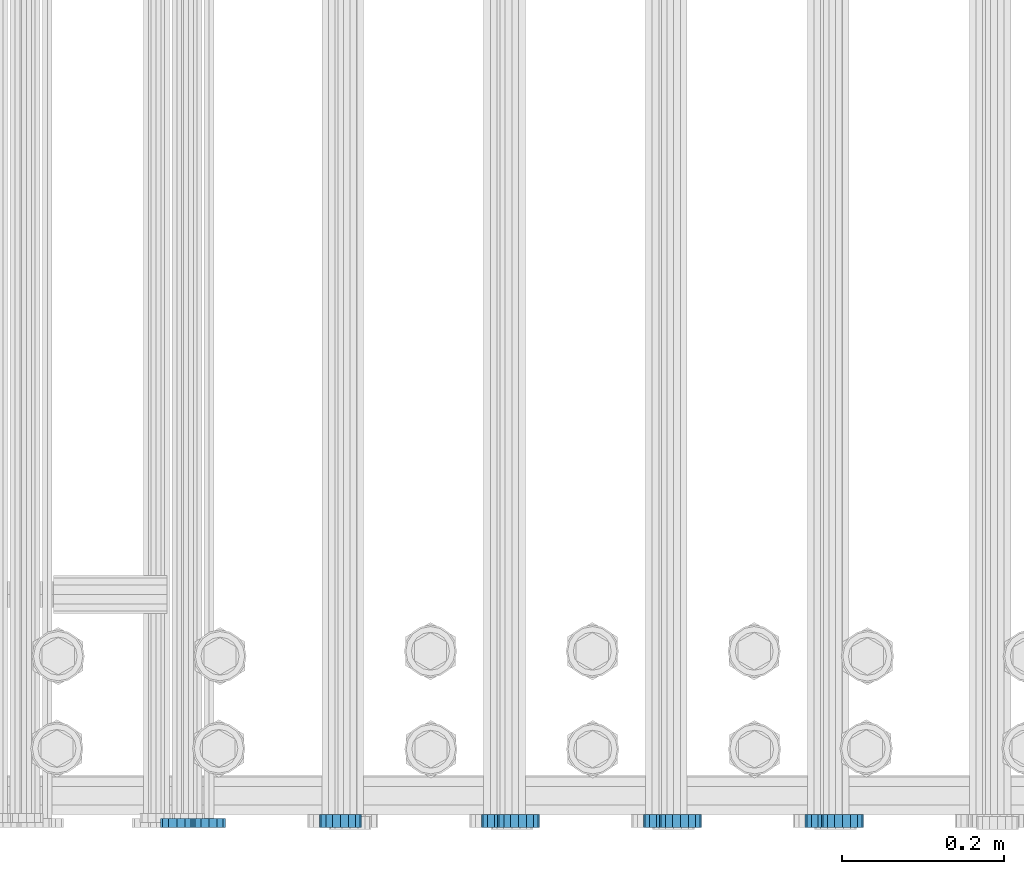
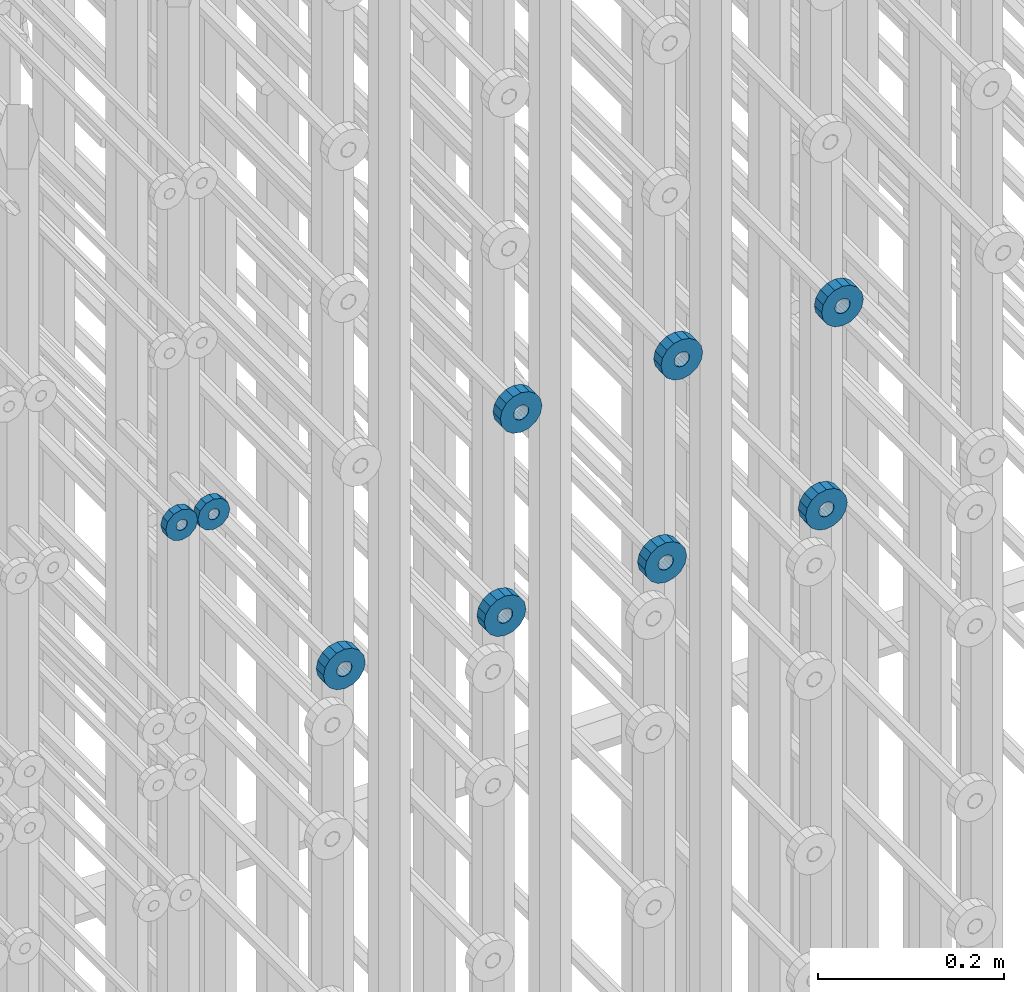
# One storey, part 128 of 177: 9 beams.
"""IFC2X3 building model written with IfcOpenShell, lengths in millimetres."""

from ifc_helpers import new_model, si_unit, frame, origin_with_axes, place, context, subcontext, project, spatial, faceted_brep, material, type_object, element, save


model = new_model("IFC2X3")

# Units and contexts
model_context_1 = context("Model", 3, precision=1e-05, world=origin_with_axes())
model_context_2 = context("Model", 3, precision=1e-05, world=origin_with_axes())
body_context = subcontext(model_context_2, "Body", "Model", "MODEL_VIEW")
ifc_project = project(units=[si_unit("LENGTHUNIT", "METRE", prefix="MILLI"), si_unit("AREAUNIT", "SQUARE_METRE"), si_unit("VOLUMEUNIT", "CUBIC_METRE"), si_unit("MASSUNIT", "GRAM", prefix="KILO"), si_unit("TIMEUNIT", "SECOND"), si_unit("PLANEANGLEUNIT", "RADIAN"), si_unit("SOLIDANGLEUNIT", "STERADIAN"), si_unit("THERMODYNAMICTEMPERATUREUNIT", "DEGREE_CELSIUS"), si_unit("LUMINOUSINTENSITYUNIT", "LUMEN")], contexts=[model_context_1])

# Site, building, storey
site_placement = place(None, origin_with_axes())
site = spatial("IfcSite", under=ifc_project, at=site_placement, CompositionType="ELEMENT")
building_placement = place(site_placement, origin_with_axes())
building = spatial("IfcBuilding", under=site, at=building_placement, Name="Undefined", CompositionType="ELEMENT")
storey_placement = place(building_placement, origin_with_axes())
storey = spatial("IfcBuildingStorey", under=building, at=storey_placement, Name="Undefined", CompositionType="ELEMENT", Elevation=0.0)

# Beams
ifc_material = material(Name="STEEL/Steel_Undefined")
beam_type_1 = type_object("IfcBeamType", PredefinedType="NOTDEFINED")
beam_1_placement = place(storey_placement, frame((2031961.99847313, 6205070.98588033, 21128.9868114202), z_axis=(0.0, 0.0, -1.0), x_axis=(0.0, -1.0, 0.0)))
element("IfcBeam", 1, at=beam_1_placement, inside=storey, type_object=beam_type_1, material=ifc_material, context=body_context, shape_type="Brep", body=[
    faceted_brep([(-3.63797880709171e-12, -7.0, -2.3283064365387e-10), (-8.62348444298797e-13, -6.06217782649107, 3.5), (10.9999999999964, -6.06217782665044, 3.49999999976717), (10.9999999999964, -7.0, -2.3283064365387e-10), (-3.63797880709171e-12, -3.5, 6.06217782618478), (11.0, -3.5, 6.06217782618478), (-1.72469688859759e-12, 0.0, 7.0), (11.0, 0.0, 6.99999999976717), (-3.63797880709171e-12, 3.5, 6.06217782618478), (11.0, 3.5, 6.06217782618478), (-8.62348444298795e-13, 6.06217782649107, 3.5), (10.9999999999964, 6.06217782665044, 3.49999999976717), (-3.63797880709171e-12, 7.0, -2.3283064365387e-10), (10.9999999999964, 7.0, -2.3283064365387e-10), (8.62348444298797e-13, 6.06217782649107, -3.5), (10.9999999999964, 6.06217782665044, -3.50000000023283), (-3.63797880709171e-12, 3.5, -6.06217782665044), (10.9999999999964, 3.5, -6.06217782665044), (1.72469688859759e-12, -2.72004641033163e-15, -7.0), (10.9999999999964, 0.0, -7.00000000023283), (-3.63797880709171e-12, -3.5, -6.06217782665044), (10.9999999999964, -3.5, -6.06217782665044), (8.62348444298796e-13, -6.06217782649107, -3.5), (10.9999999999964, -6.06217782665044, -3.50000000023283), (0.0, -20.0000000009313, 0.0), (0.0, -17.320508075878, -10.0), (10.9999999999964, -17.320508075878, -10.0000000002328), (10.9999999999964, -20.0, -2.3283064365387e-10), (0.0, -10.0000000009313, -17.3205080756452), (11.0, -10.0, -17.320508075878), (0.0, -1.86264514923096e-09, -19.9999999998836), (10.9999999999964, 0.0, -20.0000000002328), (0.0, 9.99999999906868, -17.3205080755288), (11.0, 10.0, -17.320508075878), (0.0, 17.320508075878, -10.0), (10.9999999999964, 17.320508075878, -10.0000000002328), (0.0, 19.9999999990687, 0.0), (10.9999999999964, 20.0, -2.3283064365387e-10), (0.0, 17.3205080740154, 10.0), (11.0, 17.320508075878, 9.99999999976717), (0.0, 9.99999999906868, 17.3205080757616), (10.9999999999964, 10.0, 17.3205080754124), (0.0, 0.0, 20.0000000001164), (10.9999999999964, 0.0, 19.9999999997672), (0.0, -10.0000000009313, 17.3205080757616), (10.9999999999964, -10.0, 17.3205080754124), (0.0, -17.3205080777407, 10.0000000001164), (11.0, -17.320508075878, 9.99999999976717)], [[[0, 1, 2, 3]], [[1, 4, 5, 2]], [[4, 6, 7, 5]], [[6, 8, 9, 7]], [[8, 10, 11, 9]], [[10, 12, 13, 11]], [[12, 14, 15, 13]], [[14, 16, 17, 15]], [[16, 18, 19, 17]], [[18, 20, 21, 19]], [[20, 22, 23, 21]], [[22, 0, 3, 23]], [[24, 25, 26, 27]], [[25, 28, 29, 26]], [[28, 30, 31, 29]], [[30, 32, 33, 31]], [[32, 34, 35, 33]], [[34, 36, 37, 35]], [[36, 38, 39, 37]], [[38, 40, 41, 39]], [[40, 42, 43, 41]], [[42, 44, 45, 43]], [[44, 46, 47, 45]], [[46, 24, 27, 47]], [[29, 31, 33, 35, 37, 39, 41, 43, 45, 47, 27, 26], [5, 7, 9, 11, 13, 15, 17, 19, 21, 23, 3, 2]], [[46, 44, 42, 40, 38, 36, 34, 32, 30, 28, 25, 24], [22, 20, 18, 16, 14, 12, 10, 8, 6, 4, 1, 0]]]),
])
beam_2_placement = place(storey_placement, frame((2031921.99847313, 6205070.98588033, 21128.9868114202), z_axis=(0.0, 0.0, -1.0), x_axis=(0.0, -1.0, 0.0)))
element("IfcBeam", 2, at=beam_2_placement, inside=storey, type_object=beam_type_1, material=ifc_material, context=body_context, shape_type="Brep", body=[
    faceted_brep([(-3.63797880709171e-12, -7.0, -2.3283064365387e-10), (-8.62348444298797e-13, -6.06217782649107, 3.5), (10.9999999999964, -6.06217782665044, 3.49999999976717), (10.9999999999964, -7.0, -2.3283064365387e-10), (-3.63797880709171e-12, -3.5, 6.06217782618478), (11.0, -3.5, 6.06217782618478), (-1.72469688859759e-12, 0.0, 7.0), (11.0, 0.0, 6.99999999976717), (-3.63797880709171e-12, 3.5, 6.06217782618478), (11.0, 3.5, 6.06217782618478), (-8.62348444298795e-13, 6.06217782649107, 3.5), (10.9999999999964, 6.06217782665044, 3.49999999976717), (-3.63797880709171e-12, 7.0, -2.3283064365387e-10), (10.9999999999964, 7.0, -2.3283064365387e-10), (8.62348444298797e-13, 6.06217782649107, -3.5), (10.9999999999964, 6.06217782665044, -3.50000000023283), (-3.63797880709171e-12, 3.5, -6.06217782665044), (10.9999999999964, 3.5, -6.06217782665044), (1.72469688859759e-12, -2.72004641033163e-15, -7.0), (10.9999999999964, 0.0, -7.00000000023283), (-3.63797880709171e-12, -3.5, -6.06217782665044), (10.9999999999964, -3.5, -6.06217782665044), (8.62348444298796e-13, -6.06217782649107, -3.5), (10.9999999999964, -6.06217782665044, -3.50000000023283), (0.0, -20.0000000009313, 0.0), (0.0, -17.320508075878, -10.0), (10.9999999999964, -17.320508075878, -10.0000000002328), (10.9999999999964, -20.0, -2.3283064365387e-10), (0.0, -10.0000000009313, -17.3205080756452), (11.0, -10.0, -17.320508075878), (0.0, -1.86264514923096e-09, -19.9999999998836), (10.9999999999964, 0.0, -20.0000000002328), (0.0, 9.99999999906868, -17.3205080755288), (11.0, 10.0, -17.320508075878), (0.0, 17.320508075878, -10.0), (10.9999999999964, 17.320508075878, -10.0000000002328), (0.0, 19.9999999990687, 0.0), (10.9999999999964, 20.0, -2.3283064365387e-10), (0.0, 17.3205080740154, 10.0), (11.0, 17.320508075878, 9.99999999976717), (0.0, 9.99999999906868, 17.3205080757616), (10.9999999999964, 10.0, 17.3205080754124), (0.0, 0.0, 20.0000000001164), (10.9999999999964, 0.0, 19.9999999997672), (0.0, -10.0000000009313, 17.3205080757616), (10.9999999999964, -10.0, 17.3205080754124), (0.0, -17.3205080777407, 10.0000000001164), (11.0, -17.320508075878, 9.99999999976717)], [[[0, 1, 2, 3]], [[1, 4, 5, 2]], [[4, 6, 7, 5]], [[6, 8, 9, 7]], [[8, 10, 11, 9]], [[10, 12, 13, 11]], [[12, 14, 15, 13]], [[14, 16, 17, 15]], [[16, 18, 19, 17]], [[18, 20, 21, 19]], [[20, 22, 23, 21]], [[22, 0, 3, 23]], [[24, 25, 26, 27]], [[25, 28, 29, 26]], [[28, 30, 31, 29]], [[30, 32, 33, 31]], [[32, 34, 35, 33]], [[34, 36, 37, 35]], [[36, 38, 39, 37]], [[38, 40, 41, 39]], [[40, 42, 43, 41]], [[42, 44, 45, 43]], [[44, 46, 47, 45]], [[46, 24, 27, 47]], [[29, 31, 33, 35, 37, 39, 41, 43, 45, 47, 27, 26], [5, 7, 9, 11, 13, 15, 17, 19, 21, 23, 3, 2]], [[46, 44, 42, 40, 38, 36, 34, 32, 30, 28, 25, 24], [22, 20, 18, 16, 14, 12, 10, 8, 6, 4, 1, 0]]]),
])
beam_type_2 = type_object("IfcBeamType", PredefinedType="NOTDEFINED")
beam_3_placement = place(storey_placement, frame((2032724.49847313, 6205075.98588568, 20868.4868124751), z_axis=(0.0, 0.0, -1.0), x_axis=(0.0, -1.0, 0.0)))
element("IfcBeam", 3, at=beam_3_placement, inside=storey, type_object=beam_type_2, material=ifc_material, context=body_context, shape_type="Brep", body=[
    faceted_brep([(0.0, -9.5, 0.0), (0.0, -8.77685555908829, 3.63549260746731), (16.0, -8.77685555908829, 3.63549260746731), (16.0, -9.5, 0.0), (0.0, -6.71751442085952, 6.71751442127061), (16.0, -6.71751442085952, 6.71751442127061), (0.0, -3.63549260701984, 8.77685555885546), (16.0, -3.63549260701984, 8.77685555885546), (-2.02452244836415e-12, 0.0, 9.5), (16.0, 0.0, 9.5), (0.0, 3.63549260701984, 8.77685555885546), (16.0, 3.63549260701984, 8.77685555885546), (0.0, 6.71751442085952, 6.71751442127061), (16.0, 6.71751442085952, 6.71751442127061), (0.0, 8.77685555908829, 3.63549260746731), (16.0, 8.77685555908829, 3.63549260746731), (0.0, 9.5, 0.0), (16.0, 9.5, 0.0), (0.0, 8.77685555908829, -3.63549260746731), (16.0, 8.77685555908829, -3.63549260746731), (0.0, 6.71751442085952, -6.71751442127061), (16.0, 6.71751442085952, -6.71751442127061), (0.0, 3.63549260701984, -8.77685555885546), (16.0, 3.63549260701984, -8.77685555885546), (2.02452244836415e-12, -3.69149155687865e-15, -9.5), (16.0, 0.0, -9.5), (0.0, -3.63549260701984, -8.77685555885546), (16.0, -3.63549260701984, -8.77685555885546), (0.0, -6.71751442085952, -6.71751442127061), (16.0, -6.71751442085952, -6.71751442127061), (0.0, -8.77685555908829, -3.63549260746731), (16.0, -8.77685555908829, -3.63549260746731), (0.0, -26.0, 0.0), (0.0, -24.0208678450435, -9.94976924149159), (16.0, -24.0208678450435, -9.94976924149159), (16.0, -26.0, 0.0), (0.0, -18.3847763109952, -18.3847763108497), (16.0, -18.3847763109952, -18.3847763108497), (0.0, -9.94976924173534, -24.0208678452946), (16.0, -9.94976924173534, -24.0208678452946), (0.0, 0.0, -26.0), (16.0, 0.0, -26.0), (0.0, 9.94976924173534, -24.0208678452946), (16.0, 9.94976924173534, -24.0208678452946), (0.0, 18.3847763109952, -18.3847763108497), (16.0, 18.3847763109952, -18.3847763108497), (0.0, 24.0208678450435, -9.94976924149159), (16.0, 24.0208678450435, -9.94976924149159), (0.0, 26.0, 0.0), (16.0, 26.0, 0.0), (0.0, 24.0208678450435, 9.94976924149159), (16.0, 24.0208678450435, 9.94976924149159), (0.0, 18.3847763109952, 18.3847763108497), (16.0, 18.3847763109952, 18.3847763108497), (0.0, 9.94976924173534, 24.0208678452946), (16.0, 9.94976924173534, 24.0208678452946), (0.0, 0.0, 26.0), (16.0, 0.0, 26.0), (0.0, -9.94976924173534, 24.0208678452946), (16.0, -9.94976924173534, 24.0208678452946), (0.0, -18.3847763109952, 18.3847763108497), (16.0, -18.3847763109952, 18.3847763108497), (0.0, -24.0208678450435, 9.94976924149159), (16.0, -24.0208678450435, 9.94976924149159)], [[[0, 1, 2, 3]], [[1, 4, 5, 2]], [[4, 6, 7, 5]], [[6, 8, 9, 7]], [[8, 10, 11, 9]], [[10, 12, 13, 11]], [[12, 14, 15, 13]], [[14, 16, 17, 15]], [[16, 18, 19, 17]], [[18, 20, 21, 19]], [[20, 22, 23, 21]], [[22, 24, 25, 23]], [[24, 26, 27, 25]], [[26, 28, 29, 27]], [[28, 30, 31, 29]], [[30, 0, 3, 31]], [[32, 33, 34, 35]], [[33, 36, 37, 34]], [[36, 38, 39, 37]], [[38, 40, 41, 39]], [[40, 42, 43, 41]], [[42, 44, 45, 43]], [[44, 46, 47, 45]], [[46, 48, 49, 47]], [[48, 50, 51, 49]], [[50, 52, 53, 51]], [[52, 54, 55, 53]], [[54, 56, 57, 55]], [[56, 58, 59, 57]], [[58, 60, 61, 59]], [[60, 62, 63, 61]], [[62, 32, 35, 63]], [[37, 39, 41, 43, 45, 47, 49, 51, 53, 55, 57, 59, 61, 63, 35, 34], [5, 7, 9, 11, 13, 15, 17, 19, 21, 23, 25, 27, 29, 31, 3, 2]], [[62, 60, 58, 56, 54, 52, 50, 48, 46, 44, 42, 40, 38, 36, 33, 32], [30, 28, 26, 24, 22, 20, 18, 16, 14, 12, 10, 8, 6, 4, 1, 0]]]),
])
beam_4_placement = place(storey_placement, frame((2032524.49847313, 6205075.98588568, 20868.4868124752), z_axis=(0.0, 0.0, -1.0), x_axis=(0.0, -1.0, 0.0)))
element("IfcBeam", 4, at=beam_4_placement, inside=storey, type_object=beam_type_2, material=ifc_material, context=body_context, shape_type="Brep", body=[
    faceted_brep([(0.0, -9.5, 0.0), (0.0, -8.77685555908829, 3.63549260746731), (16.0, -8.77685555908829, 3.63549260746731), (16.0, -9.5, 0.0), (0.0, -6.71751442085952, 6.71751442127061), (16.0, -6.71751442085952, 6.71751442127061), (0.0, -3.63549260701984, 8.77685555885546), (16.0, -3.63549260701984, 8.77685555885546), (-2.02452244836415e-12, 0.0, 9.5), (16.0, 0.0, 9.5), (0.0, 3.63549260701984, 8.77685555885546), (16.0, 3.63549260701984, 8.77685555885546), (0.0, 6.71751442085952, 6.71751442127061), (16.0, 6.71751442085952, 6.71751442127061), (0.0, 8.77685555908829, 3.63549260746731), (16.0, 8.77685555908829, 3.63549260746731), (0.0, 9.5, 0.0), (16.0, 9.5, 0.0), (0.0, 8.77685555908829, -3.63549260746731), (16.0, 8.77685555908829, -3.63549260746731), (0.0, 6.71751442085952, -6.71751442127061), (16.0, 6.71751442085952, -6.71751442127061), (0.0, 3.63549260701984, -8.77685555885546), (16.0, 3.63549260701984, -8.77685555885546), (2.02452244836415e-12, -3.69149155687865e-15, -9.5), (16.0, 0.0, -9.5), (0.0, -3.63549260701984, -8.77685555885546), (16.0, -3.63549260701984, -8.77685555885546), (0.0, -6.71751442085952, -6.71751442127061), (16.0, -6.71751442085952, -6.71751442127061), (0.0, -8.77685555908829, -3.63549260746731), (16.0, -8.77685555908829, -3.63549260746731), (0.0, -26.0, 0.0), (0.0, -24.0208678450435, -9.94976924149159), (16.0, -24.0208678450435, -9.94976924149159), (16.0, -26.0, 0.0), (0.0, -18.3847763109952, -18.3847763108497), (16.0, -18.3847763109952, -18.3847763108497), (0.0, -9.94976924173534, -24.0208678452946), (16.0, -9.94976924173534, -24.0208678452946), (0.0, 0.0, -26.0), (16.0, 0.0, -26.0), (0.0, 9.94976924173534, -24.0208678452946), (16.0, 9.94976924173534, -24.0208678452946), (0.0, 18.3847763109952, -18.3847763108497), (16.0, 18.3847763109952, -18.3847763108497), (0.0, 24.0208678450435, -9.94976924149159), (16.0, 24.0208678450435, -9.94976924149159), (0.0, 26.0, 0.0), (16.0, 26.0, 0.0), (0.0, 24.0208678450435, 9.94976924149159), (16.0, 24.0208678450435, 9.94976924149159), (0.0, 18.3847763109952, 18.3847763108497), (16.0, 18.3847763109952, 18.3847763108497), (0.0, 9.94976924173534, 24.0208678452946), (16.0, 9.94976924173534, 24.0208678452946), (0.0, 0.0, 26.0), (16.0, 0.0, 26.0), (0.0, -9.94976924173534, 24.0208678452946), (16.0, -9.94976924173534, 24.0208678452946), (0.0, -18.3847763109952, 18.3847763108497), (16.0, -18.3847763109952, 18.3847763108497), (0.0, -24.0208678450435, 9.94976924149159), (16.0, -24.0208678450435, 9.94976924149159)], [[[0, 1, 2, 3]], [[1, 4, 5, 2]], [[4, 6, 7, 5]], [[6, 8, 9, 7]], [[8, 10, 11, 9]], [[10, 12, 13, 11]], [[12, 14, 15, 13]], [[14, 16, 17, 15]], [[16, 18, 19, 17]], [[18, 20, 21, 19]], [[20, 22, 23, 21]], [[22, 24, 25, 23]], [[24, 26, 27, 25]], [[26, 28, 29, 27]], [[28, 30, 31, 29]], [[30, 0, 3, 31]], [[32, 33, 34, 35]], [[33, 36, 37, 34]], [[36, 38, 39, 37]], [[38, 40, 41, 39]], [[40, 42, 43, 41]], [[42, 44, 45, 43]], [[44, 46, 47, 45]], [[46, 48, 49, 47]], [[48, 50, 51, 49]], [[50, 52, 53, 51]], [[52, 54, 55, 53]], [[54, 56, 57, 55]], [[56, 58, 59, 57]], [[58, 60, 61, 59]], [[60, 62, 63, 61]], [[62, 32, 35, 63]], [[37, 39, 41, 43, 45, 47, 49, 51, 53, 55, 57, 59, 61, 63, 35, 34], [5, 7, 9, 11, 13, 15, 17, 19, 21, 23, 25, 27, 29, 31, 3, 2]], [[62, 60, 58, 56, 54, 52, 50, 48, 46, 44, 42, 40, 38, 36, 33, 32], [30, 28, 26, 24, 22, 20, 18, 16, 14, 12, 10, 8, 6, 4, 1, 0]]]),
])
beam_5_placement = place(storey_placement, frame((2032324.49847313, 6205075.98588568, 20868.4868124752), z_axis=(0.0, 0.0, -1.0), x_axis=(0.0, -1.0, 0.0)))
element("IfcBeam", 5, at=beam_5_placement, inside=storey, type_object=beam_type_2, material=ifc_material, context=body_context, shape_type="Brep", body=[
    faceted_brep([(0.0, -9.5, 0.0), (0.0, -8.77685555908829, 3.63549260746731), (16.0, -8.77685555908829, 3.63549260746731), (16.0, -9.5, 0.0), (0.0, -6.71751442085952, 6.71751442127061), (16.0, -6.71751442085952, 6.71751442127061), (0.0, -3.63549260701984, 8.77685555885546), (16.0, -3.63549260701984, 8.77685555885546), (-2.02452244836415e-12, 0.0, 9.5), (16.0, 0.0, 9.5), (0.0, 3.63549260701984, 8.77685555885546), (16.0, 3.63549260701984, 8.77685555885546), (0.0, 6.71751442085952, 6.71751442127061), (16.0, 6.71751442085952, 6.71751442127061), (0.0, 8.77685555908829, 3.63549260746731), (16.0, 8.77685555908829, 3.63549260746731), (0.0, 9.5, 0.0), (16.0, 9.5, 0.0), (0.0, 8.77685555908829, -3.63549260746731), (16.0, 8.77685555908829, -3.63549260746731), (0.0, 6.71751442085952, -6.71751442127061), (16.0, 6.71751442085952, -6.71751442127061), (0.0, 3.63549260701984, -8.77685555885546), (16.0, 3.63549260701984, -8.77685555885546), (2.02452244836415e-12, -3.69149155687865e-15, -9.5), (16.0, 0.0, -9.5), (0.0, -3.63549260701984, -8.77685555885546), (16.0, -3.63549260701984, -8.77685555885546), (0.0, -6.71751442085952, -6.71751442127061), (16.0, -6.71751442085952, -6.71751442127061), (0.0, -8.77685555908829, -3.63549260746731), (16.0, -8.77685555908829, -3.63549260746731), (0.0, -26.0, 0.0), (0.0, -24.0208678450435, -9.94976924149159), (16.0, -24.0208678450435, -9.94976924149159), (16.0, -26.0, 0.0), (0.0, -18.3847763109952, -18.3847763108497), (16.0, -18.3847763109952, -18.3847763108497), (0.0, -9.94976924173534, -24.0208678452946), (16.0, -9.94976924173534, -24.0208678452946), (0.0, 0.0, -26.0), (16.0, 0.0, -26.0), (0.0, 9.94976924173534, -24.0208678452946), (16.0, 9.94976924173534, -24.0208678452946), (0.0, 18.3847763109952, -18.3847763108497), (16.0, 18.3847763109952, -18.3847763108497), (0.0, 24.0208678450435, -9.94976924149159), (16.0, 24.0208678450435, -9.94976924149159), (0.0, 26.0, 0.0), (16.0, 26.0, 0.0), (0.0, 24.0208678450435, 9.94976924149159), (16.0, 24.0208678450435, 9.94976924149159), (0.0, 18.3847763109952, 18.3847763108497), (16.0, 18.3847763109952, 18.3847763108497), (0.0, 9.94976924173534, 24.0208678452946), (16.0, 9.94976924173534, 24.0208678452946), (0.0, 0.0, 26.0), (16.0, 0.0, 26.0), (0.0, -9.94976924173534, 24.0208678452946), (16.0, -9.94976924173534, 24.0208678452946), (0.0, -18.3847763109952, 18.3847763108497), (16.0, -18.3847763109952, 18.3847763108497), (0.0, -24.0208678450435, 9.94976924149159), (16.0, -24.0208678450435, 9.94976924149159)], [[[0, 1, 2, 3]], [[1, 4, 5, 2]], [[4, 6, 7, 5]], [[6, 8, 9, 7]], [[8, 10, 11, 9]], [[10, 12, 13, 11]], [[12, 14, 15, 13]], [[14, 16, 17, 15]], [[16, 18, 19, 17]], [[18, 20, 21, 19]], [[20, 22, 23, 21]], [[22, 24, 25, 23]], [[24, 26, 27, 25]], [[26, 28, 29, 27]], [[28, 30, 31, 29]], [[30, 0, 3, 31]], [[32, 33, 34, 35]], [[33, 36, 37, 34]], [[36, 38, 39, 37]], [[38, 40, 41, 39]], [[40, 42, 43, 41]], [[42, 44, 45, 43]], [[44, 46, 47, 45]], [[46, 48, 49, 47]], [[48, 50, 51, 49]], [[50, 52, 53, 51]], [[52, 54, 55, 53]], [[54, 56, 57, 55]], [[56, 58, 59, 57]], [[58, 60, 61, 59]], [[60, 62, 63, 61]], [[62, 32, 35, 63]], [[37, 39, 41, 43, 45, 47, 49, 51, 53, 55, 57, 59, 61, 63, 35, 34], [5, 7, 9, 11, 13, 15, 17, 19, 21, 23, 25, 27, 29, 31, 3, 2]], [[62, 60, 58, 56, 54, 52, 50, 48, 46, 44, 42, 40, 38, 36, 33, 32], [30, 28, 26, 24, 22, 20, 18, 16, 14, 12, 10, 8, 6, 4, 1, 0]]]),
])
beam_6_placement = place(storey_placement, frame((2032124.49847313, 6205075.98588568, 20868.4868124752), z_axis=(0.0, 0.0, -1.0), x_axis=(0.0, -1.0, 0.0)))
element("IfcBeam", 6, at=beam_6_placement, inside=storey, type_object=beam_type_2, material=ifc_material, context=body_context, shape_type="Brep", body=[
    faceted_brep([(0.0, -9.5, 0.0), (0.0, -8.77685555908829, 3.63549260746731), (16.0, -8.77685555908829, 3.63549260746731), (16.0, -9.5, 0.0), (0.0, -6.71751442085952, 6.71751442127061), (16.0, -6.71751442085952, 6.71751442127061), (0.0, -3.63549260701984, 8.77685555885546), (16.0, -3.63549260701984, 8.77685555885546), (-2.02452244836415e-12, 0.0, 9.5), (16.0, 0.0, 9.5), (0.0, 3.63549260701984, 8.77685555885546), (16.0, 3.63549260701984, 8.77685555885546), (0.0, 6.71751442085952, 6.71751442127061), (16.0, 6.71751442085952, 6.71751442127061), (0.0, 8.77685555908829, 3.63549260746731), (16.0, 8.77685555908829, 3.63549260746731), (0.0, 9.5, 0.0), (16.0, 9.5, 0.0), (0.0, 8.77685555908829, -3.63549260746731), (16.0, 8.77685555908829, -3.63549260746731), (0.0, 6.71751442085952, -6.71751442127061), (16.0, 6.71751442085952, -6.71751442127061), (0.0, 3.63549260701984, -8.77685555885546), (16.0, 3.63549260701984, -8.77685555885546), (2.02452244836415e-12, -3.69149155687865e-15, -9.5), (16.0, 0.0, -9.5), (0.0, -3.63549260701984, -8.77685555885546), (16.0, -3.63549260701984, -8.77685555885546), (0.0, -6.71751442085952, -6.71751442127061), (16.0, -6.71751442085952, -6.71751442127061), (0.0, -8.77685555908829, -3.63549260746731), (16.0, -8.77685555908829, -3.63549260746731), (0.0, -26.0, 0.0), (0.0, -24.0208678450435, -9.94976924149159), (16.0, -24.0208678450435, -9.94976924149159), (16.0, -26.0, 0.0), (0.0, -18.3847763109952, -18.3847763108497), (16.0, -18.3847763109952, -18.3847763108497), (0.0, -9.94976924173534, -24.0208678452946), (16.0, -9.94976924173534, -24.0208678452946), (0.0, 0.0, -26.0), (16.0, 0.0, -26.0), (0.0, 9.94976924173534, -24.0208678452946), (16.0, 9.94976924173534, -24.0208678452946), (0.0, 18.3847763109952, -18.3847763108497), (16.0, 18.3847763109952, -18.3847763108497), (0.0, 24.0208678450435, -9.94976924149159), (16.0, 24.0208678450435, -9.94976924149159), (0.0, 26.0, 0.0), (16.0, 26.0, 0.0), (0.0, 24.0208678450435, 9.94976924149159), (16.0, 24.0208678450435, 9.94976924149159), (0.0, 18.3847763109952, 18.3847763108497), (16.0, 18.3847763109952, 18.3847763108497), (0.0, 9.94976924173534, 24.0208678452946), (16.0, 9.94976924173534, 24.0208678452946), (0.0, 0.0, 26.0), (16.0, 0.0, 26.0), (0.0, -9.94976924173534, 24.0208678452946), (16.0, -9.94976924173534, 24.0208678452946), (0.0, -18.3847763109952, 18.3847763108497), (16.0, -18.3847763109952, 18.3847763108497), (0.0, -24.0208678450435, 9.94976924149159), (16.0, -24.0208678450435, 9.94976924149159)], [[[0, 1, 2, 3]], [[1, 4, 5, 2]], [[4, 6, 7, 5]], [[6, 8, 9, 7]], [[8, 10, 11, 9]], [[10, 12, 13, 11]], [[12, 14, 15, 13]], [[14, 16, 17, 15]], [[16, 18, 19, 17]], [[18, 20, 21, 19]], [[20, 22, 23, 21]], [[22, 24, 25, 23]], [[24, 26, 27, 25]], [[26, 28, 29, 27]], [[28, 30, 31, 29]], [[30, 0, 3, 31]], [[32, 33, 34, 35]], [[33, 36, 37, 34]], [[36, 38, 39, 37]], [[38, 40, 41, 39]], [[40, 42, 43, 41]], [[42, 44, 45, 43]], [[44, 46, 47, 45]], [[46, 48, 49, 47]], [[48, 50, 51, 49]], [[50, 52, 53, 51]], [[52, 54, 55, 53]], [[54, 56, 57, 55]], [[56, 58, 59, 57]], [[58, 60, 61, 59]], [[60, 62, 63, 61]], [[62, 32, 35, 63]], [[37, 39, 41, 43, 45, 47, 49, 51, 53, 55, 57, 59, 61, 63, 35, 34], [5, 7, 9, 11, 13, 15, 17, 19, 21, 23, 25, 27, 29, 31, 3, 2]], [[62, 60, 58, 56, 54, 52, 50, 48, 46, 44, 42, 40, 38, 36, 33, 32], [30, 28, 26, 24, 22, 20, 18, 16, 14, 12, 10, 8, 6, 4, 1, 0]]]),
])
beam_7_placement = place(storey_placement, frame((2032744.49847313, 6205075.98588578, 21128.9868125736), z_axis=(0.0, 0.0, -1.0), x_axis=(0.0, -1.0, 0.0)))
element("IfcBeam", 7, at=beam_7_placement, inside=storey, type_object=beam_type_2, material=ifc_material, context=body_context, shape_type="Brep", body=[
    faceted_brep([(0.0, -9.5, 0.0), (0.0, -8.77685555908829, 3.63549260746731), (16.0, -8.77685555908829, 3.63549260746731), (16.0, -9.5, 0.0), (0.0, -6.71751442085952, 6.71751442127061), (16.0, -6.71751442085952, 6.71751442127061), (0.0, -3.63549260701984, 8.77685555885546), (16.0, -3.63549260701984, 8.77685555885546), (-2.02452244836415e-12, 0.0, 9.5), (16.0, 0.0, 9.5), (0.0, 3.63549260701984, 8.77685555885546), (16.0, 3.63549260701984, 8.77685555885546), (0.0, 6.71751442085952, 6.71751442127061), (16.0, 6.71751442085952, 6.71751442127061), (0.0, 8.77685555908829, 3.63549260746731), (16.0, 8.77685555908829, 3.63549260746731), (0.0, 9.5, 0.0), (16.0, 9.5, 0.0), (0.0, 8.77685555908829, -3.63549260746731), (16.0, 8.77685555908829, -3.63549260746731), (0.0, 6.71751442085952, -6.71751442127061), (16.0, 6.71751442085952, -6.71751442127061), (0.0, 3.63549260701984, -8.77685555885546), (16.0, 3.63549260701984, -8.77685555885546), (2.02452244836415e-12, -3.69149155687865e-15, -9.5), (16.0, 0.0, -9.5), (0.0, -3.63549260701984, -8.77685555885546), (16.0, -3.63549260701984, -8.77685555885546), (0.0, -6.71751442085952, -6.71751442127061), (16.0, -6.71751442085952, -6.71751442127061), (0.0, -8.77685555908829, -3.63549260746731), (16.0, -8.77685555908829, -3.63549260746731), (0.0, -26.0, 0.0), (0.0, -24.0208678450435, -9.94976924149159), (16.0, -24.0208678450435, -9.94976924149159), (16.0, -26.0, 0.0), (0.0, -18.3847763109952, -18.3847763108497), (16.0, -18.3847763109952, -18.3847763108497), (0.0, -9.94976924173534, -24.0208678452946), (16.0, -9.94976924173534, -24.0208678452946), (0.0, 0.0, -26.0), (16.0, 0.0, -26.0), (0.0, 9.94976924173534, -24.0208678452946), (16.0, 9.94976924173534, -24.0208678452946), (0.0, 18.3847763109952, -18.3847763108497), (16.0, 18.3847763109952, -18.3847763108497), (0.0, 24.0208678450435, -9.94976924149159), (16.0, 24.0208678450435, -9.94976924149159), (0.0, 26.0, 0.0), (16.0, 26.0, 0.0), (0.0, 24.0208678450435, 9.94976924149159), (16.0, 24.0208678450435, 9.94976924149159), (0.0, 18.3847763109952, 18.3847763108497), (16.0, 18.3847763109952, 18.3847763108497), (0.0, 9.94976924173534, 24.0208678452946), (16.0, 9.94976924173534, 24.0208678452946), (0.0, 0.0, 26.0), (16.0, 0.0, 26.0), (0.0, -9.94976924173534, 24.0208678452946), (16.0, -9.94976924173534, 24.0208678452946), (0.0, -18.3847763109952, 18.3847763108497), (16.0, -18.3847763109952, 18.3847763108497), (0.0, -24.0208678450435, 9.94976924149159), (16.0, -24.0208678450435, 9.94976924149159)], [[[0, 1, 2, 3]], [[1, 4, 5, 2]], [[4, 6, 7, 5]], [[6, 8, 9, 7]], [[8, 10, 11, 9]], [[10, 12, 13, 11]], [[12, 14, 15, 13]], [[14, 16, 17, 15]], [[16, 18, 19, 17]], [[18, 20, 21, 19]], [[20, 22, 23, 21]], [[22, 24, 25, 23]], [[24, 26, 27, 25]], [[26, 28, 29, 27]], [[28, 30, 31, 29]], [[30, 0, 3, 31]], [[32, 33, 34, 35]], [[33, 36, 37, 34]], [[36, 38, 39, 37]], [[38, 40, 41, 39]], [[40, 42, 43, 41]], [[42, 44, 45, 43]], [[44, 46, 47, 45]], [[46, 48, 49, 47]], [[48, 50, 51, 49]], [[50, 52, 53, 51]], [[52, 54, 55, 53]], [[54, 56, 57, 55]], [[56, 58, 59, 57]], [[58, 60, 61, 59]], [[60, 62, 63, 61]], [[62, 32, 35, 63]], [[37, 39, 41, 43, 45, 47, 49, 51, 53, 55, 57, 59, 61, 63, 35, 34], [5, 7, 9, 11, 13, 15, 17, 19, 21, 23, 25, 27, 29, 31, 3, 2]], [[62, 60, 58, 56, 54, 52, 50, 48, 46, 44, 42, 40, 38, 36, 33, 32], [30, 28, 26, 24, 22, 20, 18, 16, 14, 12, 10, 8, 6, 4, 1, 0]]]),
])
beam_8_placement = place(storey_placement, frame((2032544.49847313, 6205075.98588578, 21128.9868125736), z_axis=(0.0, 0.0, -1.0), x_axis=(0.0, -1.0, 0.0)))
element("IfcBeam", 8, at=beam_8_placement, inside=storey, type_object=beam_type_2, material=ifc_material, context=body_context, shape_type="Brep", body=[
    faceted_brep([(0.0, -9.5, 0.0), (0.0, -8.77685555908829, 3.63549260746731), (16.0, -8.77685555908829, 3.63549260746731), (16.0, -9.5, 0.0), (0.0, -6.71751442085952, 6.71751442127061), (16.0, -6.71751442085952, 6.71751442127061), (0.0, -3.63549260701984, 8.77685555885546), (16.0, -3.63549260701984, 8.77685555885546), (-2.02452244836415e-12, 0.0, 9.5), (16.0, 0.0, 9.5), (0.0, 3.63549260701984, 8.77685555885546), (16.0, 3.63549260701984, 8.77685555885546), (0.0, 6.71751442085952, 6.71751442127061), (16.0, 6.71751442085952, 6.71751442127061), (0.0, 8.77685555908829, 3.63549260746731), (16.0, 8.77685555908829, 3.63549260746731), (0.0, 9.5, 0.0), (16.0, 9.5, 0.0), (0.0, 8.77685555908829, -3.63549260746731), (16.0, 8.77685555908829, -3.63549260746731), (0.0, 6.71751442085952, -6.71751442127061), (16.0, 6.71751442085952, -6.71751442127061), (0.0, 3.63549260701984, -8.77685555885546), (16.0, 3.63549260701984, -8.77685555885546), (2.02452244836415e-12, -3.69149155687865e-15, -9.5), (16.0, 0.0, -9.5), (0.0, -3.63549260701984, -8.77685555885546), (16.0, -3.63549260701984, -8.77685555885546), (0.0, -6.71751442085952, -6.71751442127061), (16.0, -6.71751442085952, -6.71751442127061), (0.0, -8.77685555908829, -3.63549260746731), (16.0, -8.77685555908829, -3.63549260746731), (0.0, -26.0, 0.0), (0.0, -24.0208678450435, -9.94976924149159), (16.0, -24.0208678450435, -9.94976924149159), (16.0, -26.0, 0.0), (0.0, -18.3847763109952, -18.3847763108497), (16.0, -18.3847763109952, -18.3847763108497), (0.0, -9.94976924173534, -24.0208678452946), (16.0, -9.94976924173534, -24.0208678452946), (0.0, 0.0, -26.0), (16.0, 0.0, -26.0), (0.0, 9.94976924173534, -24.0208678452946), (16.0, 9.94976924173534, -24.0208678452946), (0.0, 18.3847763109952, -18.3847763108497), (16.0, 18.3847763109952, -18.3847763108497), (0.0, 24.0208678450435, -9.94976924149159), (16.0, 24.0208678450435, -9.94976924149159), (0.0, 26.0, 0.0), (16.0, 26.0, 0.0), (0.0, 24.0208678450435, 9.94976924149159), (16.0, 24.0208678450435, 9.94976924149159), (0.0, 18.3847763109952, 18.3847763108497), (16.0, 18.3847763109952, 18.3847763108497), (0.0, 9.94976924173534, 24.0208678452946), (16.0, 9.94976924173534, 24.0208678452946), (0.0, 0.0, 26.0), (16.0, 0.0, 26.0), (0.0, -9.94976924173534, 24.0208678452946), (16.0, -9.94976924173534, 24.0208678452946), (0.0, -18.3847763109952, 18.3847763108497), (16.0, -18.3847763109952, 18.3847763108497), (0.0, -24.0208678450435, 9.94976924149159), (16.0, -24.0208678450435, 9.94976924149159)], [[[0, 1, 2, 3]], [[1, 4, 5, 2]], [[4, 6, 7, 5]], [[6, 8, 9, 7]], [[8, 10, 11, 9]], [[10, 12, 13, 11]], [[12, 14, 15, 13]], [[14, 16, 17, 15]], [[16, 18, 19, 17]], [[18, 20, 21, 19]], [[20, 22, 23, 21]], [[22, 24, 25, 23]], [[24, 26, 27, 25]], [[26, 28, 29, 27]], [[28, 30, 31, 29]], [[30, 0, 3, 31]], [[32, 33, 34, 35]], [[33, 36, 37, 34]], [[36, 38, 39, 37]], [[38, 40, 41, 39]], [[40, 42, 43, 41]], [[42, 44, 45, 43]], [[44, 46, 47, 45]], [[46, 48, 49, 47]], [[48, 50, 51, 49]], [[50, 52, 53, 51]], [[52, 54, 55, 53]], [[54, 56, 57, 55]], [[56, 58, 59, 57]], [[58, 60, 61, 59]], [[60, 62, 63, 61]], [[62, 32, 35, 63]], [[37, 39, 41, 43, 45, 47, 49, 51, 53, 55, 57, 59, 61, 63, 35, 34], [5, 7, 9, 11, 13, 15, 17, 19, 21, 23, 25, 27, 29, 31, 3, 2]], [[62, 60, 58, 56, 54, 52, 50, 48, 46, 44, 42, 40, 38, 36, 33, 32], [30, 28, 26, 24, 22, 20, 18, 16, 14, 12, 10, 8, 6, 4, 1, 0]]]),
])
beam_9_placement = place(storey_placement, frame((2032344.49847313, 6205075.98588578, 21128.9868125736), z_axis=(0.0, 0.0, -1.0), x_axis=(0.0, -1.0, 0.0)))
element("IfcBeam", 9, at=beam_9_placement, inside=storey, type_object=beam_type_2, material=ifc_material, context=body_context, shape_type="Brep", body=[
    faceted_brep([(0.0, -9.5, 0.0), (0.0, -8.77685555908829, 3.63549260746731), (16.0, -8.77685555908829, 3.63549260746731), (16.0, -9.5, 0.0), (0.0, -6.71751442085952, 6.71751442127061), (16.0, -6.71751442085952, 6.71751442127061), (0.0, -3.63549260701984, 8.77685555885546), (16.0, -3.63549260701984, 8.77685555885546), (-2.02452244836415e-12, 0.0, 9.5), (16.0, 0.0, 9.5), (0.0, 3.63549260701984, 8.77685555885546), (16.0, 3.63549260701984, 8.77685555885546), (0.0, 6.71751442085952, 6.71751442127061), (16.0, 6.71751442085952, 6.71751442127061), (0.0, 8.77685555908829, 3.63549260746731), (16.0, 8.77685555908829, 3.63549260746731), (0.0, 9.5, 0.0), (16.0, 9.5, 0.0), (0.0, 8.77685555908829, -3.63549260746731), (16.0, 8.77685555908829, -3.63549260746731), (0.0, 6.71751442085952, -6.71751442127061), (16.0, 6.71751442085952, -6.71751442127061), (0.0, 3.63549260701984, -8.77685555885546), (16.0, 3.63549260701984, -8.77685555885546), (2.02452244836415e-12, -3.69149155687865e-15, -9.5), (16.0, 0.0, -9.5), (0.0, -3.63549260701984, -8.77685555885546), (16.0, -3.63549260701984, -8.77685555885546), (0.0, -6.71751442085952, -6.71751442127061), (16.0, -6.71751442085952, -6.71751442127061), (0.0, -8.77685555908829, -3.63549260746731), (16.0, -8.77685555908829, -3.63549260746731), (0.0, -26.0, 0.0), (0.0, -24.0208678450435, -9.94976924149159), (16.0, -24.0208678450435, -9.94976924149159), (16.0, -26.0, 0.0), (0.0, -18.3847763109952, -18.3847763108497), (16.0, -18.3847763109952, -18.3847763108497), (0.0, -9.94976924173534, -24.0208678452946), (16.0, -9.94976924173534, -24.0208678452946), (0.0, 0.0, -26.0), (16.0, 0.0, -26.0), (0.0, 9.94976924173534, -24.0208678452946), (16.0, 9.94976924173534, -24.0208678452946), (0.0, 18.3847763109952, -18.3847763108497), (16.0, 18.3847763109952, -18.3847763108497), (0.0, 24.0208678450435, -9.94976924149159), (16.0, 24.0208678450435, -9.94976924149159), (0.0, 26.0, 0.0), (16.0, 26.0, 0.0), (0.0, 24.0208678450435, 9.94976924149159), (16.0, 24.0208678450435, 9.94976924149159), (0.0, 18.3847763109952, 18.3847763108497), (16.0, 18.3847763109952, 18.3847763108497), (0.0, 9.94976924173534, 24.0208678452946), (16.0, 9.94976924173534, 24.0208678452946), (0.0, 0.0, 26.0), (16.0, 0.0, 26.0), (0.0, -9.94976924173534, 24.0208678452946), (16.0, -9.94976924173534, 24.0208678452946), (0.0, -18.3847763109952, 18.3847763108497), (16.0, -18.3847763109952, 18.3847763108497), (0.0, -24.0208678450435, 9.94976924149159), (16.0, -24.0208678450435, 9.94976924149159)], [[[0, 1, 2, 3]], [[1, 4, 5, 2]], [[4, 6, 7, 5]], [[6, 8, 9, 7]], [[8, 10, 11, 9]], [[10, 12, 13, 11]], [[12, 14, 15, 13]], [[14, 16, 17, 15]], [[16, 18, 19, 17]], [[18, 20, 21, 19]], [[20, 22, 23, 21]], [[22, 24, 25, 23]], [[24, 26, 27, 25]], [[26, 28, 29, 27]], [[28, 30, 31, 29]], [[30, 0, 3, 31]], [[32, 33, 34, 35]], [[33, 36, 37, 34]], [[36, 38, 39, 37]], [[38, 40, 41, 39]], [[40, 42, 43, 41]], [[42, 44, 45, 43]], [[44, 46, 47, 45]], [[46, 48, 49, 47]], [[48, 50, 51, 49]], [[50, 52, 53, 51]], [[52, 54, 55, 53]], [[54, 56, 57, 55]], [[56, 58, 59, 57]], [[58, 60, 61, 59]], [[60, 62, 63, 61]], [[62, 32, 35, 63]], [[37, 39, 41, 43, 45, 47, 49, 51, 53, 55, 57, 59, 61, 63, 35, 34], [5, 7, 9, 11, 13, 15, 17, 19, 21, 23, 25, 27, 29, 31, 3, 2]], [[62, 60, 58, 56, 54, 52, 50, 48, 46, 44, 42, 40, 38, 36, 33, 32], [30, 28, 26, 24, 22, 20, 18, 16, 14, 12, 10, 8, 6, 4, 1, 0]]]),
])

save(model, "model.ifc")
